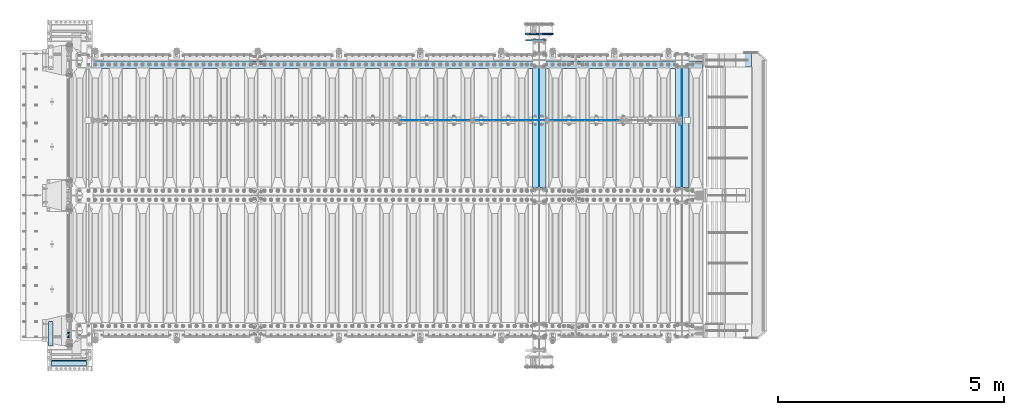
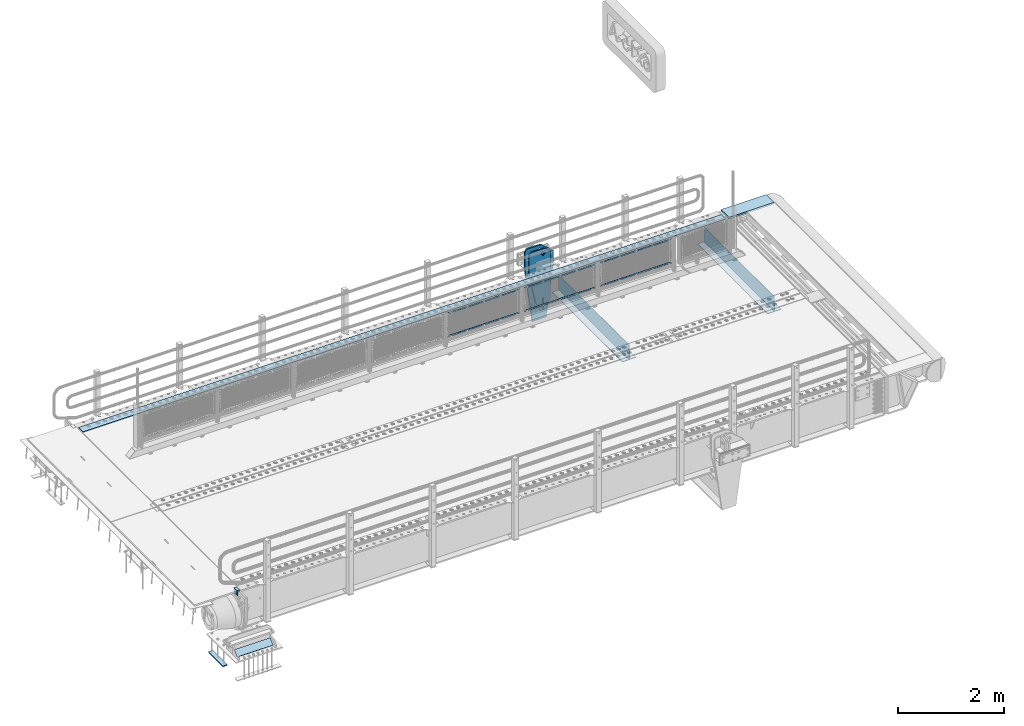
# One storey, part 153 of 193: 18 plates.
"""IFC2X3 building model written with IfcOpenShell, lengths in millimetres."""

from ifc_helpers import new_model, si_unit, frame, origin_with_axes, place, context, subcontext, project, spatial, faceted_brep, material, type_object, element, save


model = new_model("IFC2X3")

# Units and contexts
model_context = context("Model", 3, precision=1e-05, world=origin_with_axes())
body_context = subcontext(model_context, "Body", "Model", "MODEL_VIEW")
ifc_project = project(units=[si_unit("LENGTHUNIT", "METRE", prefix="MILLI"), si_unit("AREAUNIT", "SQUARE_METRE"), si_unit("VOLUMEUNIT", "CUBIC_METRE"), si_unit("MASSUNIT", "GRAM", prefix="KILO"), si_unit("TIMEUNIT", "SECOND"), si_unit("PLANEANGLEUNIT", "RADIAN"), si_unit("SOLIDANGLEUNIT", "STERADIAN"), si_unit("THERMODYNAMICTEMPERATUREUNIT", "DEGREE_CELSIUS"), si_unit("LUMINOUSINTENSITYUNIT", "LUMEN")], contexts=[model_context])

# Site, building, storey
site_placement = place(None, origin_with_axes())
site = spatial("IfcSite", under=ifc_project, at=site_placement, CompositionType="ELEMENT")
building_placement = place(site_placement, origin_with_axes())
building = spatial("IfcBuilding", under=site, at=building_placement, Name="Standard", CompositionType="ELEMENT")
storey_placement = place(building_placement, origin_with_axes())
storey = spatial("IfcBuildingStorey", under=building, at=storey_placement, Name="Undefined", CompositionType="ELEMENT", Elevation=0.0)

# Plates
ifc_material_1 = material()
plate_type_1 = type_object("IfcPlateType", PredefinedType="NOTDEFINED")
plate_1_placement = place(storey_placement, frame((-42460.00000006, 23910.0000004319, -15.9997623857934), z_axis=(-1.0, 0.0, 0.0), x_axis=(0.0, -4.95099997756316e-06, 0.999999999987744)))
element("IfcPlate", 1, at=plate_1_placement, inside=storey, type_object=plate_type_1, material=ifc_material_1, context=body_context, shape_type="Brep", body=[
    faceted_brep([(3.5527136788005e-15, -60.0, 0.0), (-0.000933120085687023, -60.0, 60.0), (-0.000933120085687023, 60.0, 59.9999999999927), (0.0, 60.0, -7.27595761418343e-12), (24.9991450303709, -60.0, 60.0), (24.9991450303709, 60.0, 59.9999999999927), (26.544215218168, -60.0000000000036, 59.7552873850873), (26.544215218168, 60.0, 59.75528738508), (27.9380461396139, -60.0000000000036, 59.0451032459096), (27.9380461396139, 60.0, 59.0451032459096), (29.0442025908961, -60.0000000000036, 57.9389639895744), (29.0442025908961, 60.0, 57.9389639895744), (29.7544083969366, -60.0, 56.5451441080368), (29.7544083969366, 60.0, 56.5451441080295), (29.9991450297669, -60.0000000000036, 55.0000777244568), (29.9991450297669, 60.0, 55.0000777244495), (29.999922274335, -60.0, 5.00007772445679), (29.999922274335, 59.9999999999964, 5.00007772444951), (29.7552240705896, -60.0, 3.45497416452417), (29.7552240705896, 60.0000000000036, 3.45497416452417), (29.0450346578116, -60.0, 2.06111146690819), (29.0450346578116, 59.9999999999964, 2.06111146690819), (27.9388736885072, -60.0000000000036, 0.954933302316931), (27.9388736885072, 59.9999999999964, 0.954933302316931), (26.5450220308766, -60.0000000000036, 0.244722222181736), (26.5450220308766, 60.0, 0.244722222181736), (24.9999222749392, -60.0, 0.0), (24.9999222749392, 60.0, -7.27595761418343e-12)], [[[0, 1, 2, 3]], [[1, 4, 5, 2]], [[4, 6, 7, 5]], [[6, 8, 9, 7]], [[8, 10, 11, 9]], [[10, 12, 13, 11]], [[12, 14, 15, 13]], [[14, 16, 17, 15]], [[16, 18, 19, 17]], [[18, 20, 21, 19]], [[20, 22, 23, 21]], [[22, 24, 25, 23]], [[24, 26, 27, 25]], [[26, 0, 3, 27]], [[5, 7, 9, 11, 13, 15, 17, 19, 21, 23, 25, 27, 3, 2]], [[26, 24, 22, 20, 18, 16, 14, 12, 10, 8, 6, 4, 1, 0]]]),
])
ifc_material_2 = material(Name="STEEL/S355N")
plate_type_2 = type_object("IfcPlateType", PredefinedType="NOTDEFINED")
plate_2_placement = place(storey_placement, frame((-42510.0, 23970.0004459811, -106.00008741594), z_axis=(1.0000003385235e-09, -0.999999999987744, -4.95099999993936e-06), x_axis=(0.0, -4.95099997756316e-06, 0.999999999987744)))
element("IfcPlate", 2, at=plate_2_placement, inside=storey, type_object=plate_type_2, material=ifc_material_2, context=body_context, shape_type="Brep", body=[
    faceted_brep([(0.0, -10.0, 0.0), (5.70725632087488e-07, -10.0, 120.0), (5.70725632087488e-07, 10.0, 120.0), (0.0, 10.0, 0.0), (89.9999999999979, -10.0, 120.000000000004), (89.9999999999979, 10.0, 120.000000000004), (90.0, -10.0, 1.09139364212751e-11), (90.0, 10.0, 1.09139364212751e-11)], [[[0, 1, 2, 3]], [[1, 4, 5, 2]], [[4, 6, 7, 5]], [[6, 0, 3, 7]], [[5, 7, 3, 2]], [[6, 4, 1, 0]]]),
])
plate_type_3 = type_object("IfcPlateType", PredefinedType="NOTDEFINED")
plate_3_placement = place(storey_placement, frame((-31900.0000000678, 30440.0000000043, -945.000018238359), z_axis=(-0.901283188008789, 0.0, 0.433230441004224), x_axis=(-0.433230441004221, 0.0, -0.90128318800879)))
element("IfcPlate", 3, at=plate_3_placement, inside=storey, type_object=plate_type_3, material=ifc_material_2, context=body_context, shape_type="Brep", body=[
    faceted_brep([(-929.368911797765, -15.0000000000182, 583.25255503177), (-929.368911797765, 14.9999999999818, 583.25255503177), (-937.308302015212, 14.9999999999818, 596.689503306545), (-937.308302015212, -15.0000000000182, 596.689503306545), (-939.501244651428, 14.9999999999818, 612.141897896323), (-939.501244651428, -15.0000000000182, 612.141897896323), (-935.613884069126, 14.9999999999818, 627.257251801111), (-935.613884069126, -15.0000000000182, 627.257251801111), (-926.238035677947, 14.9999999999818, 639.734389409932), (-926.238035677947, -15.0000000000182, 639.734389409932), (-912.80108740317, 14.9999999999818, 647.673779627385), (-912.80108740317, -15.0000000000182, 647.673779627385), (-897.348692813393, 14.9999999999818, 649.8667222636), (-897.348692813393, -15.0000000000182, 649.8667222636), (-882.233338908603, 14.9999999999818, 645.979361681293), (-882.233338908603, -15.0000000000182, 645.979361681293), (-869.756201299781, 14.9999999999818, 636.603513290116), (-869.756201299781, -15.0000000000182, 636.603513290116), (-861.816811082334, 14.9999999999818, 623.166565015341), (-861.816811082334, -15.0000000000182, 623.166565015341), (-859.623868446119, 14.9999999999818, 607.714170425563), (-859.623868446119, -15.0000000000182, 607.714170425563), (-863.511229028423, 14.9999999999818, 592.598816520771), (-863.511229028423, -15.0000000000182, 592.598816520771), (-872.8870774196, 14.9999999999818, 580.121678911954), (-872.8870774196, -15.0000000000182, 580.121678911954), (-886.324025694375, 14.9999999999818, 572.182288694501), (-886.324025694375, -15.0000000000182, 572.182288694501), (-901.776420284152, 14.9999999999818, 569.989346058286), (-901.776420284152, -15.0000000000182, 569.989346058286), (-916.891774188942, 14.9999999999818, 573.876706640593), (-916.891774188942, -15.0000000000182, 573.876706640593), (264.349946032446, -15.0, 42.1349881382121), (264.349946032446, 15.0, 42.1349881382121), (15.5957837831356, 14.9999999999854, 161.706590989248), (15.5957837831356, -15.0000000000109, 161.706590989248), (244.096420288086, -15.0, 6.91215973347425e-11), (244.096420288086, 15.0, 6.91215973347425e-11), (0.0, -15.0, 0.0), (0.0, 15.0, 0.0), (-976.801696777344, -15.0, 469.530822753906), (-976.801696777344, 15.0, 469.530822753906), (-1005.61097945758, -15.0, 584.572341407267), (-1005.61097945758, 15.0, 584.572341407267), (-1008.62086606945, -15.0, 603.379087420442), (-1008.62086606945, 15.0, 603.379087420442), (-1008.34154488122, -15.0, 622.423117789454), (-1008.34154488122, 15.0, 622.423117789454), (-1004.78138982914, -15.0, 641.133500175365), (-1004.78138982914, 15.0, 641.133500175365), (-998.047132923919, -15.0, 658.949304871177), (-998.047132923919, 15.0, 658.949304871177), (-903.392995239108, -15.0, 855.865677422371), (-903.392995239108, 15.0, 855.865677422371), (-891.96589330134, -15.0, 873.346258360976), (-891.96589330134, 15.0, 873.346258360976), (-876.403853384376, -15.0, 887.273651593932), (-876.403853384376, 15.0, 887.273651593932), (-857.767402657568, -15.0, 896.698728407944), (-857.767402657568, 15.0, 896.698728407944), (-837.32658428003, -15.0, 900.979185474582), (-837.32658428003, 15.0, 900.979185474582), (-816.474406068941, -15.0, 899.823316755235), (-816.474406068941, 15.0, 899.823316755235), (-796.631909330703, -15.0, 893.309892783484), (-796.631909330703, 15.0, 893.309892783484), (-427.105804443359, -15.0, 715.685424804688), (-427.105804443359, 15.0, 715.685424804688), (138.633743286133, -15.0, 288.410614013668), (138.633743286133, 15.0, 288.410614013668), (291.101928710936, -15.0, 97.7892227172815), (291.101928710936, 15.0, 97.7892227172815), (270.848403445216, -15.0, 55.654235574897), (270.848403445216, 15.0, 55.654235574897), (22.094240398199, -15.0000000000109, 175.22583880938), (22.094240398199, 14.9999999999854, 175.22583880938), (-855.850321886393, -15.0, 588.916357840073), (-852.143242428174, -15.0, 592.234043611839), (-847.175983297808, -15.0, 591.958700695603), (-843.85829752604, -15.0, 588.251621237385), (-844.133640442278, -15.0, 583.284362107021), (-847.840719900496, -15.0, 579.966676335251), (-852.807979030862, -15.0, 580.242019251487), (-856.125664802632, -15.0, 583.949098709705), (-844.133640442278, 15.0, 583.284362107021), (-847.840719900496, 15.0, 579.966676335251), (-843.85829752604, 15.0, 588.251621237385), (-847.175983297808, 15.0, 591.958700695603), (-852.143242428174, 15.0, 592.234043611839), (-855.850321886393, 15.0, 588.916357840073), (-856.125664802632, 15.0, 583.949098709705), (-852.807979030862, 15.0, 580.242019251487)], [[[0, 1, 2, 3]], [[3, 2, 4, 5]], [[5, 4, 6, 7]], [[7, 6, 8, 9]], [[9, 8, 10, 11]], [[11, 10, 12, 13]], [[13, 12, 14, 15]], [[15, 14, 16, 17]], [[17, 16, 18, 19]], [[19, 18, 20, 21]], [[21, 20, 22, 23]], [[23, 22, 24, 25]], [[25, 24, 26, 27]], [[27, 26, 28, 29]], [[29, 28, 30, 31]], [[31, 30, 1, 0]], [[32, 33, 34, 35]], [[36, 37, 33, 32]], [[36, 38, 39, 37]], [[38, 40, 41, 39]], [[40, 42, 43, 41]], [[42, 44, 45, 43]], [[44, 46, 47, 45]], [[46, 48, 49, 47]], [[48, 50, 51, 49]], [[50, 52, 53, 51]], [[52, 54, 55, 53]], [[54, 56, 57, 55]], [[56, 58, 59, 57]], [[58, 60, 61, 59]], [[60, 62, 63, 61]], [[62, 64, 65, 63]], [[64, 66, 67, 65]], [[66, 68, 69, 67]], [[68, 70, 71, 69]], [[71, 70, 72, 73]], [[74, 75, 73, 72]], [[35, 34, 75, 74]], [[72, 70, 68, 66, 64, 62, 60, 58, 56, 54, 52, 50, 48, 46, 44, 42, 40, 38, 36, 32, 35, 74], [3, 5, 7, 9, 11, 13, 15, 17, 19, 21, 23, 25, 27, 29, 31, 0], [76, 77, 78, 79, 80, 81, 82, 83]], [[80, 84, 85, 81]], [[79, 86, 84, 80]], [[78, 87, 86, 79]], [[77, 88, 87, 78]], [[76, 89, 88, 77]], [[83, 90, 89, 76]], [[82, 91, 90, 83]], [[81, 85, 91, 82]], [[37, 39, 41, 43, 45, 47, 49, 51, 53, 55, 57, 59, 61, 63, 65, 67, 69, 71, 73, 75, 34, 33], [26, 24, 22, 20, 18, 16, 14, 12, 10, 8, 6, 4, 2, 1, 30, 28], [84, 86, 87, 88, 89, 90, 91, 85]]]),
])
plate_type_4 = type_object("IfcPlateType", PredefinedType="NOTDEFINED")
for number, where, z_axis, x_axis in (
    (4, (-28895.0, 29825.0, 0.0), (0.0, 0.0, -1.0), (0.0, -1.0, 0.0)),
    (5, (-32060.0, 29825.0, 0.0), (0.0, 0.0, -1.0), (0.0, -1.0, 0.0)),
):
    element("IfcPlate", number, at=place(storey_placement, frame(where, z_axis=z_axis, x_axis=x_axis)), inside=storey, type_object=plate_type_4, material=ifc_material_2, context=body_context, shape_type="Brep", body=[
        faceted_brep([(0.0, -5.0, 0.0), (0.0, -5.0, 336.0), (0.0, 5.0, 336.0), (0.0, 5.0, 0.0), (2650.0, -5.0, 336.0), (2650.0, 5.0, 336.0), (2650.0, -5.0, 0.0), (2650.0, 5.0, 0.0)], [[[0, 1, 2, 3]], [[1, 4, 5, 2]], [[4, 6, 7, 5]], [[6, 0, 3, 7]], [[5, 7, 3, 2]], [[6, 4, 1, 0]]]),
    ])
plate_type_5 = type_object("IfcPlateType", PredefinedType="NOTDEFINED")
for number, where, z_axis, x_axis in (
    (6, (-29045.0, 27175.0, -343.0), (0.0, 1.0, 0.0), (1.0, 0.0, 0.0)),
    (7, (-32210.0, 27175.0, -343.0), (0.0, 1.0, 0.0), (1.0, 0.0, 0.0)),
):
    element("IfcPlate", number, at=place(storey_placement, frame(where, z_axis=z_axis, x_axis=x_axis)), inside=storey, type_object=plate_type_5, material=ifc_material_2, context=body_context, shape_type="Brep", body=[
        faceted_brep([(0.0, -7.0, 0.0), (0.0, -7.0, 2650.0), (0.0, 7.0, 2650.0), (0.0, 7.0, 0.0), (300.0, -7.0, 2650.0), (300.0, 7.0, 2650.0), (300.0, -7.0, 0.0), (300.0, 7.0, 0.0)], [[[0, 1, 2, 3]], [[1, 4, 5, 2]], [[4, 6, 7, 5]], [[6, 0, 3, 7]], [[5, 7, 3, 2]], [[6, 4, 1, 0]]]),
    ])
ifc_material_3 = material(Name="Misc_Undefined")
plate_type_6 = type_object("IfcPlateType", PredefinedType="NOTDEFINED")
plate_4_placement = place(storey_placement, frame((-31827.4949882696, 28670.5, 351.520303374641), z_axis=(0.0, 0.0, 1.0), x_axis=(1.0, 0.0, 0.0)))
element("IfcPlate", 8, at=plate_4_placement, inside=storey, type_object=plate_type_6, material=ifc_material_3, context=body_context, shape_type="Brep", body=[
    faceted_brep([(0.0, -1.49999999999636, 3.63797880709171e-12), (35.0002975463831, -1.5, 34.9996948242187), (35.0002975463831, 1.5, 34.9996948242187), (0.0, 1.50000000000364, 7.27595761418343e-12), (1515.99035644531, -1.5, 34.9999923706054), (1515.99035644531, 1.5, 34.9999923706054), (1550.98999023437, -1.5, 4.43037606601138e-09), (1550.98999023437, 1.5, 4.43037606601138e-09)], [[[0, 1, 2, 3]], [[1, 4, 5, 2]], [[4, 6, 7, 5]], [[6, 0, 3, 7]], [[5, 7, 3, 2]], [[6, 4, 1, 0]]]),
])
plate_5_placement = place(storey_placement, frame((-30276.4999998124, 28670.5, 914.520000175701), z_axis=(-0.707103624179499, 0.0, 0.707109938179501), x_axis=(-0.707109938179501, 0.0, -0.707103624179499)))
element("IfcPlate", 9, at=plate_5_placement, inside=storey, type_object=plate_type_6, material=ifc_material_3, context=body_context, shape_type="Brep", body=[
    faceted_brep([(0.0, -1.49999999999636, 3.63797880709171e-12), (1096.7275390625, -1.5, 1096.7177734375), (1096.7275390625, 1.5, 1096.7177734375), (0.0, 1.50000000000364, 7.27595761418343e-12), (1096.72045898438, -1.5, 1047.21337890625), (1096.72045898438, 1.5, 1047.21337890625), (49.4976959228552, -1.5, -1.01863406598568e-10), (49.4976959228552, 1.5, -1.01863406598568e-10)], [[[0, 1, 2, 3]], [[1, 4, 5, 2]], [[4, 6, 7, 5]], [[6, 0, 3, 7]], [[5, 7, 3, 2]], [[6, 4, 1, 0]]]),
])
plate_6_placement = place(storey_placement, frame((-33485.4949882696, 28670.5, 351.520303374641), z_axis=(0.0, 0.0, 1.0), x_axis=(1.0, 0.0, 0.0)))
element("IfcPlate", 10, at=plate_6_placement, inside=storey, type_object=plate_type_6, material=ifc_material_3, context=body_context, shape_type="Brep", body=[
    faceted_brep([(0.0, -1.49999999999636, 3.63797880709171e-12), (35.0002975463831, -1.5, 34.9996948242187), (35.0002975463831, 1.5, 34.9996948242187), (0.0, 1.50000000000364, 7.27595761418343e-12), (1515.99035644531, -1.5, 34.9999923706054), (1515.99035644531, 1.5, 34.9999923706054), (1550.98999023437, -1.5, 4.43037606601138e-09), (1550.98999023437, 1.5, 4.43037606601138e-09)], [[[0, 1, 2, 3]], [[1, 4, 5, 2]], [[4, 6, 7, 5]], [[6, 0, 3, 7]], [[5, 7, 3, 2]], [[6, 4, 1, 0]]]),
])
plate_7_placement = place(storey_placement, frame((-31934.4999998124, 28670.5, 914.520000175701), z_axis=(-0.707103624179499, 0.0, 0.707109938179501), x_axis=(-0.707109938179501, 0.0, -0.707103624179499)))
element("IfcPlate", 11, at=plate_7_placement, inside=storey, type_object=plate_type_6, material=ifc_material_3, context=body_context, shape_type="Brep", body=[
    faceted_brep([(0.0, -1.49999999999636, 3.63797880709171e-12), (1096.7275390625, -1.5, 1096.7177734375), (1096.7275390625, 1.5, 1096.7177734375), (0.0, 1.50000000000364, 7.27595761418343e-12), (1096.72045898438, -1.5, 1047.21337890625), (1096.72045898438, 1.5, 1047.21337890625), (49.4976959228552, -1.5, -1.01863406598568e-10), (49.4976959228552, 1.5, -1.01863406598568e-10)], [[[0, 1, 2, 3]], [[1, 4, 5, 2]], [[4, 6, 7, 5]], [[6, 0, 3, 7]], [[5, 7, 3, 2]], [[6, 4, 1, 0]]]),
])
plate_8_placement = place(storey_placement, frame((-35143.4949882696, 28670.5, 351.520303374641), z_axis=(0.0, 0.0, 1.0), x_axis=(1.0, 0.0, 0.0)))
element("IfcPlate", 12, at=plate_8_placement, inside=storey, type_object=plate_type_6, material=ifc_material_3, context=body_context, shape_type="Brep", body=[
    faceted_brep([(0.0, -1.49999999999636, 3.63797880709171e-12), (35.0002975463831, -1.5, 34.9996948242187), (35.0002975463831, 1.5, 34.9996948242187), (0.0, 1.50000000000364, 7.27595761418343e-12), (1515.99035644531, -1.5, 34.9999923706054), (1515.99035644531, 1.5, 34.9999923706054), (1550.98999023437, -1.5, 4.43037606601138e-09), (1550.98999023437, 1.5, 4.43037606601138e-09)], [[[0, 1, 2, 3]], [[1, 4, 5, 2]], [[4, 6, 7, 5]], [[6, 0, 3, 7]], [[5, 7, 3, 2]], [[6, 4, 1, 0]]]),
])
plate_9_placement = place(storey_placement, frame((-33592.4999998124, 28670.5, 914.520000175701), z_axis=(-0.707103624179499, 0.0, 0.707109938179501), x_axis=(-0.707109938179501, 0.0, -0.707103624179499)))
element("IfcPlate", 13, at=plate_9_placement, inside=storey, type_object=plate_type_6, material=ifc_material_3, context=body_context, shape_type="Brep", body=[
    faceted_brep([(0.0, -1.49999999999636, 3.63797880709171e-12), (1096.7275390625, -1.5, 1096.7177734375), (1096.7275390625, 1.5, 1096.7177734375), (0.0, 1.50000000000364, 7.27595761418343e-12), (1096.72045898438, -1.5, 1047.21337890625), (1096.72045898438, 1.5, 1047.21337890625), (49.4976959228552, -1.5, -1.01863406598568e-10), (49.4976959228552, 1.5, -1.01863406598568e-10)], [[[0, 1, 2, 3]], [[1, 4, 5, 2]], [[4, 6, 7, 5]], [[6, 0, 3, 7]], [[5, 7, 3, 2]], [[6, 4, 1, 0]]]),
])
plate_type_7 = type_object("IfcPlateType", PredefinedType="NOTDEFINED")
plate_10_placement = place(storey_placement, frame((-42095.0, 23234.6428652468, -1017.14966545662), z_axis=(-1.0, 0.0, 0.0), x_axis=(0.0, 0.723355636225727, 0.690475650215469)))
element("IfcPlate", 14, at=plate_10_placement, inside=storey, type_object=plate_type_7, material=ifc_material_2, context=body_context, shape_type="Brep", body=[
    faceted_brep([(0.0, -15.0, 0.0), (-3.63797880709171e-12, -14.9999999999964, 779.0), (-3.63797880709171e-12, 15.0, 779.0), (0.0, 15.0, 0.0), (152.069061279297, -15.0, 779.0), (152.069061279293, 15.0, 779.0), (152.069061279297, -15.0, 0.0), (152.069061279293, 15.0, 0.0)], [[[0, 1, 2, 3]], [[1, 4, 5, 2]], [[4, 6, 7, 5]], [[6, 0, 3, 7]], [[5, 7, 3, 2]], [[6, 4, 1, 0]]]),
])
plate_type_8 = type_object("IfcPlateType", PredefinedType="NOTDEFINED")
plate_11_placement = place(storey_placement, frame((-42939.0, 23660.0000014662, -1468.0), z_axis=(0.0, 1.0, 0.0), x_axis=(1.0, 0.0, 0.0)))
element("IfcPlate", 15, at=plate_11_placement, inside=storey, type_object=plate_type_8, material=ifc_material_2, context=body_context, shape_type="Brep", body=[
    faceted_brep([(0.0, -10.0, 0.0), (1.00942997960374e-06, -10.0, 550.0), (1.00942997960374e-06, 10.0, 550.0), (0.0, 10.0, 0.0), (100.0, -10.0, 550.0), (100.0, 10.0, 550.0), (100.0, -10.0, 0.0), (100.0, 10.0, 0.0)], [[[0, 1, 2, 3]], [[1, 4, 5, 2]], [[4, 6, 7, 5]], [[6, 0, 3, 7]], [[5, 7, 3, 2]], [[6, 4, 1, 0]]]),
])
plate_type_9 = type_object("IfcPlateType", PredefinedType="NOTDEFINED")
plate_12_placement = place(storey_placement, frame((-31910.0000000678, 30580.0000000043, -1470.00001823836), z_axis=(0.0, 0.0, 1.0), x_axis=(-1.0, 0.0, 0.0)))
element("IfcPlate", 16, at=plate_12_placement, inside=storey, type_object=plate_type_9, material=ifc_material_2, context=body_context, shape_type="Brep", body=[
    faceted_brep([(113.04481869996, -15.0, 1615.3073372946), (113.04481869996, 14.9999999999527, 1615.3073372946), (121.715728752948, 14.9999999999527, 1628.28427124746), (121.715728752948, -15.0, 1628.28427124746), (134.692662705809, 14.9999999999527, 1636.95518130045), (134.692662705809, -15.0, 1636.95518130045), (150.000000000411, 14.9999999999527, 1640.0), (150.000000000411, -15.0, 1640.0), (165.307337295013, 14.9999999999527, 1636.95518130045), (165.307337295013, -15.0, 1636.95518130045), (178.284271247874, 14.9999999999527, 1628.28427124746), (178.284271247874, -15.0, 1628.28427124746), (186.955181300862, 14.9999999999527, 1615.3073372946), (186.955181300862, -15.0, 1615.3073372946), (190.000000000411, 14.9999999999527, 1600.0), (190.000000000411, -15.0, 1600.0), (186.955181300862, 14.9999999999527, 1584.6926627054), (186.955181300862, -15.0, 1584.6926627054), (178.284271247874, 14.9999999999527, 1571.71572875254), (178.284271247874, -15.0, 1571.71572875254), (165.307337295013, 14.9999999999527, 1563.04481869955), (165.307337295013, -15.0, 1563.04481869955), (150.000000000411, 14.9999999999527, 1560.0), (150.000000000411, -15.0, 1560.0), (134.692662705809, 14.9999999999527, 1563.04481869955), (134.692662705809, -15.0, 1563.04481869955), (121.715728752948, 14.9999999999527, 1571.71572875254), (121.715728752948, -15.0, 1571.71572875254), (113.04481869996, 14.9999999999527, 1584.6926627054), (113.04481869996, -15.0, 1584.6926627054), (110.000000000411, 14.9999999999527, 1600.0), (110.000000000411, -15.0, 1600.0), (300.0, -15.0, 0.0), (0.0, -15.0, 0.0), (0.0, 15.0, 0.0), (300.0, 15.0, 0.0), (462.5, -15.0, 1210.0), (462.5, 15.0, 1210.0), (462.5, -15.0, 1630.0), (462.5, 15.0, 1630.0), (459.774066103124, -15.0, 1650.7055236082), (459.774066103124, 15.0, 1650.7055236082), (451.782032302755, -15.0, 1670.0), (451.782032302755, 15.0, 1670.0), (439.068542494922, -15.0, 1686.56854249492), (439.068542494922, 15.0, 1686.56854249492), (422.5, -15.0, 1699.28203230276), (422.5, 15.0, 1699.28203230276), (403.205523608201, -15.0, 1707.27406610313), (403.205523608201, 15.0, 1707.27406610313), (382.5, -15.0, 1710.0), (382.5, 15.0, 1710.0), (151.788081037081, -15.0, 1710.0), (151.788081037081, 15.0, 1710.0), (132.694887325029, -15.0, 1708.33028179541), (132.694887325029, 15.0, 1708.33028179541), (114.181334578883, -15.0, 1703.37181734316), (114.181334578883, 15.0, 1703.37181734316), (96.809466726856, -15.0, 1695.27513824985), (96.809466726856, 15.0, 1695.27513824985), (81.1066678416755, -15.0, 1684.28604765144), (81.1066678416755, 15.0, 1684.28604765144), (-162.5, -15.0, 1480.0), (-162.5, 15.0, 1480.0), (-162.5, -15.0, 1210.0), (-162.5, 15.0, 1210.0), (150.000000000411, -15.0, 1551.5), (154.596194078124, -15.0, 1549.59619407771), (156.500000000411, -15.0, 1545.0), (154.596194078124, -15.0, 1540.40380592229), (150.000000000411, -15.0, 1538.5), (145.403805922699, -15.0, 1540.40380592229), (143.500000000411, -15.0, 1545.0), (145.403805922699, -15.0, 1549.59619407771), (150.000000000411, 15.0, 1538.5), (145.403805922699, 15.0, 1540.40380592229), (154.596194078124, 15.0, 1540.40380592229), (156.500000000411, 15.0, 1545.0), (154.596194078124, 15.0, 1549.59619407771), (150.000000000411, 15.0, 1551.5), (145.403805922699, 15.0, 1549.59619407771), (143.500000000411, 15.0, 1545.0)], [[[0, 1, 2, 3]], [[3, 2, 4, 5]], [[5, 4, 6, 7]], [[7, 6, 8, 9]], [[9, 8, 10, 11]], [[11, 10, 12, 13]], [[13, 12, 14, 15]], [[15, 14, 16, 17]], [[17, 16, 18, 19]], [[19, 18, 20, 21]], [[21, 20, 22, 23]], [[23, 22, 24, 25]], [[25, 24, 26, 27]], [[27, 26, 28, 29]], [[29, 28, 30, 31]], [[31, 30, 1, 0]], [[32, 33, 34, 35]], [[36, 32, 35, 37]], [[38, 36, 37, 39]], [[40, 38, 39, 41]], [[42, 40, 41, 43]], [[44, 42, 43, 45]], [[46, 44, 45, 47]], [[48, 46, 47, 49]], [[50, 48, 49, 51]], [[52, 50, 51, 53]], [[54, 52, 53, 55]], [[56, 54, 55, 57]], [[58, 56, 57, 59]], [[60, 58, 59, 61]], [[62, 60, 61, 63]], [[64, 62, 63, 65]], [[33, 64, 65, 34]], [[32, 36, 38, 40, 42, 44, 46, 48, 50, 52, 54, 56, 58, 60, 62, 64, 33], [3, 5, 7, 9, 11, 13, 15, 17, 19, 21, 23, 25, 27, 29, 31, 0], [66, 67, 68, 69, 70, 71, 72, 73]], [[70, 74, 75, 71]], [[69, 76, 74, 70]], [[68, 77, 76, 69]], [[67, 78, 77, 68]], [[66, 79, 78, 67]], [[73, 80, 79, 66]], [[72, 81, 80, 73]], [[71, 75, 81, 72]], [[63, 61, 59, 57, 55, 53, 51, 49, 47, 45, 43, 41, 39, 37, 35, 34, 65], [26, 24, 22, 20, 18, 16, 14, 12, 10, 8, 6, 4, 2, 1, 30, 28], [74, 76, 77, 78, 79, 80, 81, 75]]]),
])
ifc_material_4 = material(Name="STEEL/S235JR")
plate_type_10 = type_object("IfcPlateType", PredefinedType="NOTDEFINED")
plate_13_placement = place(storey_placement, frame((-28433.0, 29815.0, 20.0), z_axis=(-1.0, 0.0, 0.0), x_axis=(0.0, 1.0, 0.0)))
element("IfcPlate", 17, at=plate_13_placement, inside=storey, type_object=plate_type_10, material=ifc_material_4, context=body_context, shape_type="Brep", body=[
    faceted_brep([(0.0, -6.0, 0.0), (0.0, -6.0, 13997.0), (0.0, 6.0, 13997.0), (0.0, 6.0, 0.0), (170.0, -6.0, 13997.0), (170.0, 6.0, 13997.0), (170.0, -6.0, 0.0), (170.0, 6.0, 0.0)], [[[0, 1, 2, 3]], [[1, 4, 5, 2]], [[4, 6, 7, 5]], [[6, 0, 3, 7]], [[5, 7, 3, 2]], [[6, 4, 1, 0]]]),
])
plate_type_11 = type_object("IfcPlateType", PredefinedType="NOTDEFINED")
plate_14_placement = place(storey_placement, frame((-28343.0011701095, 30150.0, -10.0000000004865), z_axis=(1.0, 0.0, 0.0), x_axis=(0.0, -1.0, 0.0)))
element("IfcPlate", 18, at=plate_14_placement, inside=storey, type_object=plate_type_11, material=ifc_material_2, context=body_context, shape_type="Brep", body=[
    faceted_brep([(300.0, 7.0, 986.0), (300.0, 20.0, 956.0), (-3.63797880709171e-11, 20.0, 956.0), (-3.63797880709171e-11, 7.0, 986.0), (0.0, 20.0, 0.0), (0.0, -20.0, 0.0), (-3.63797880709171e-11, -20.0, 986.0), (300.0, -20.0, 986.0), (300.0, -20.0, 0.0), (300.0, 20.0, 0.0)], [[[0, 1, 2, 3]], [[4, 5, 6, 3, 2]], [[6, 7, 0, 3]], [[7, 8, 9, 1, 0]], [[8, 5, 4, 9]], [[9, 4, 2, 1]], [[8, 7, 6, 5]]]),
])

save(model, "model.ifc")
